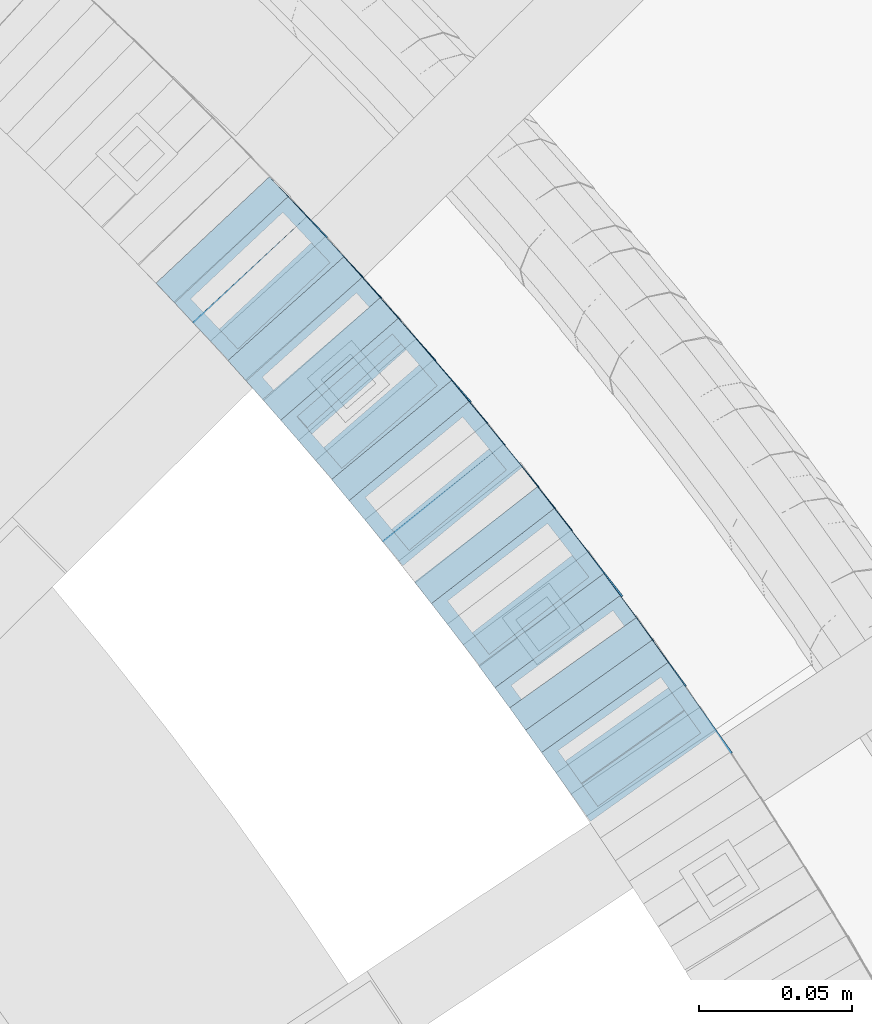
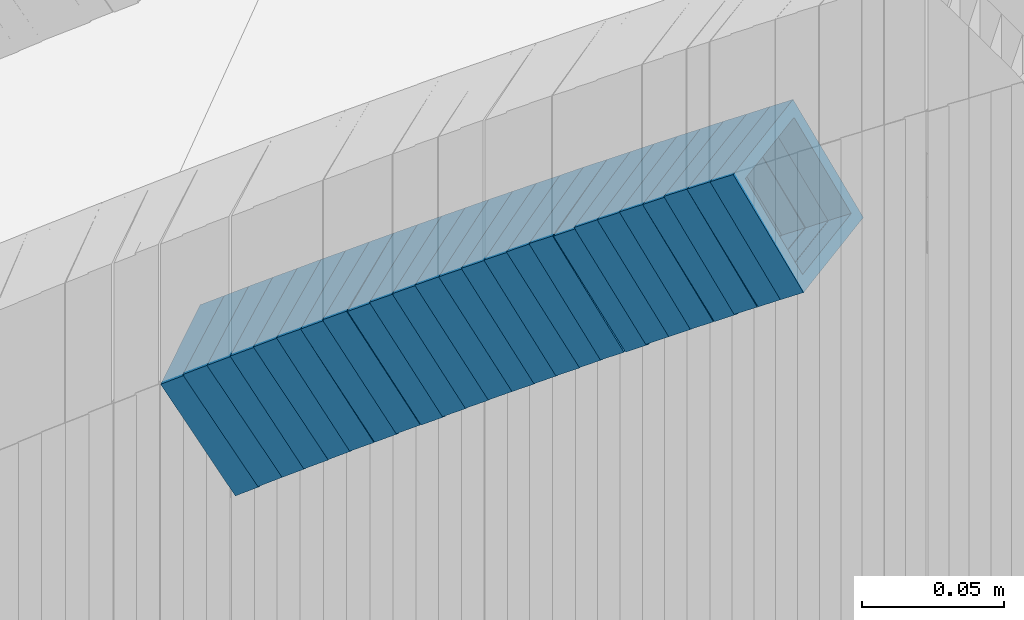
# One storey, part 804 of 975: 25 members.
"""IFC2X3 building model written with IfcOpenShell, lengths in millimetres."""

from ifc_helpers import new_model, si_unit, frame, origin_with_axes, place, context, subcontext, project, spatial, faceted_brep, material, type_object, element, save


model = new_model("IFC2X3")

# Units and contexts
model_context = context("Model", 3, precision=1e-05, world=origin_with_axes())
body_context = subcontext(model_context, "Body", "Model", "MODEL_VIEW")
ifc_project = project(units=[si_unit("LENGTHUNIT", "METRE", prefix="MILLI"), si_unit("AREAUNIT", "SQUARE_METRE"), si_unit("VOLUMEUNIT", "CUBIC_METRE"), si_unit("MASSUNIT", "GRAM", prefix="KILO"), si_unit("TIMEUNIT", "SECOND"), si_unit("PLANEANGLEUNIT", "RADIAN"), si_unit("SOLIDANGLEUNIT", "STERADIAN"), si_unit("THERMODYNAMICTEMPERATUREUNIT", "DEGREE_CELSIUS"), si_unit("LUMINOUSINTENSITYUNIT", "LUMEN")], contexts=[model_context])

# Site, building, storey
site_placement = place(None, origin_with_axes())
site = spatial("IfcSite", under=ifc_project, at=site_placement, CompositionType="ELEMENT")
building_placement = place(site_placement, origin_with_axes())
building = spatial("IfcBuilding", under=site, at=building_placement, Name="Undefined", CompositionType="ELEMENT")
storey_placement = place(building_placement, origin_with_axes())
storey = spatial("IfcBuildingStorey", under=building, at=storey_placement, Name="Undefined", CompositionType="ELEMENT", Elevation=0.0)

# Members
ifc_material = material()
member_type = type_object("IfcMemberType", Name="HSS2X2X.188_TUBES", PredefinedType="NOTDEFINED")
for number, where, z_axis, x_axis, name in (
    (1, (35883.1958449818, 4199.01896705083, 1917.16716838348), (0.814486661793431, 0.580182279771275, -2.11284714168869e-11), (0.48956492595936, -0.687273837943189, 0.536638476955618), "WALL"),
    (2, (35872.7958449818, 4213.61896705081, 1905.66716838342), (0.814486661793431, 0.580182279771275, -2.11284714168869e-11), (0.48956492595936, -0.687273837943189, 0.536638476955618), "WALL"),
):
    element("IfcMember", number, at=place(storey_placement, frame(where, z_axis=z_axis, x_axis=x_axis)), inside=storey, type_object=member_type, material=ifc_material, Name=name, ObjectType="HSS2X2X.188_TUBES", context=body_context, shape_type="Brep", body=[
        faceted_brep([(0.0, 20.6374999999753, -20.6375000000298), (0.0, -20.6375000000153, -20.6375000000153), (10.6216759506497, -20.637499999968, -20.6374999999534), (10.6216759506497, 20.6375000000262, -20.6374999999643), (0.0, -20.6374999999825, 20.6375000000335), (10.6216759506169, -20.6374999999935, 20.637500000008), (0.0, 20.6375000000116, 20.6375000000189), (10.6216759506242, 20.6375000000007, 20.6374999999971), (0.0, 25.3999999999724, -25.4000000000342), (0.0, 25.400000000016, 25.4000000000196), (10.6216759506169, 25.3999999999978, 25.3999999999869), (10.6216759506533, 25.4000000000269, -25.3999999999614), (0.0, -25.399999999976, 25.4000000000378), (10.6216759506242, -25.3999999999942, 25.4000000000051), (0.0, -25.400000000016, -25.4000000000196), (10.6216759506569, -25.3999999999614, -25.3999999999432)], [[[0, 1, 2, 3]], [[1, 4, 5, 2]], [[4, 6, 7, 5]], [[6, 0, 3, 7]], [[8, 9, 10, 11]], [[9, 12, 13, 10]], [[12, 14, 15, 13]], [[14, 8, 11, 15]], [[13, 15, 11, 10], [5, 7, 3, 2]], [[14, 12, 9, 8], [6, 4, 1, 0]]]),
    ])
member_1_placement = place(storey_placement, frame((35878.0938846065, 4206.18133450073, 1911.47557519376), z_axis=(0.814486661793431, 0.580182279771275, -2.11284714168869e-11), x_axis=(0.487088716912159, -0.683797621876746, 0.543291260902081)))
element("IfcMember", 3, at=member_1_placement, inside=storey, type_object=member_type, material=ifc_material, Name="WALL", ObjectType="HSS2X2X.188_TUBES", context=body_context, shape_type="Brep", body=[
    faceted_brep([(0.0, 20.6374999999753, -20.6375000000298), (0.0, -20.6375000000153, -20.6375000000153), (10.6831643251735, -20.6375000000498, -20.6375000000953), (10.6831643252044, 20.637499999988, -20.6375000000226), (0.0, -20.6374999999825, 20.6375000000335), (10.6831643251935, -20.6375000000135, 20.637499999968), (0.0, 20.6375000000116, 20.6375000000189), (10.6831643252244, 20.6375000000226, 20.6375000000407), (0.0, 25.3999999999724, -25.4000000000342), (0.0, 25.400000000016, 25.4000000000196), (10.6831643252317, 25.4000000000306, 25.4000000000597), (10.6831643252044, 25.3999999999905, -25.4000000000196), (0.0, -25.399999999976, 25.4000000000378), (10.6831643251917, -25.400000000016, 25.3999999999614), (0.0, -25.400000000016, -25.4000000000196), (10.6831643251644, -25.400000000056, -25.4000000001179)], [[[0, 1, 2, 3]], [[1, 4, 5, 2]], [[4, 6, 7, 5]], [[6, 0, 3, 7]], [[8, 9, 10, 11]], [[9, 12, 13, 10]], [[12, 14, 15, 13]], [[14, 8, 11, 15]], [[13, 15, 11, 10], [5, 7, 3, 2]], [[14, 12, 9, 8], [6, 4, 1, 0]]]),
])
member_2_placement = place(storey_placement, frame((35862.6148369527, 4227.80323975662, 1894.18259583676), z_axis=(0.805336884073592, 0.592817428177207, 3.1585841497872e-11), x_axis=(0.499866553847046, -0.679063997791858, 0.537592331835208)))
element("IfcMember", 4, at=member_2_placement, inside=storey, type_object=member_type, material=ifc_material, Name="WALL", ObjectType="HSS2X2X.188_TUBES", context=body_context, shape_type="Brep", body=[
    faceted_brep([(0.0, 20.6374999999753, -20.6375000000298), (0.0, -20.6375000000153, -20.6375000000153), (10.6004716875832, -20.6375000000153, -20.6375000000553), (10.6004716875814, 20.6374999999898, -20.6375000000444), (0.0, -20.6374999999825, 20.6375000000335), (10.6004716876068, -20.6375000000044, 20.6374999999862), (0.0, 20.6375000000116, 20.6375000000189), (10.6004716876032, 20.6374999999989, 20.6374999999971), (0.0, 25.3999999999724, -25.4000000000342), (0.0, 25.400000000016, 25.4000000000196), (10.600471687605, 25.4000000000015, 25.4000000000051), (10.6004716875814, 25.3999999999869, -25.4000000000487), (0.0, -25.399999999976, 25.4000000000378), (10.6004716876068, -25.4000000000015, 25.3999999999905), (0.0, -25.400000000016, -25.4000000000196), (10.6004716875814, -25.4000000000178, -25.4000000000669)], [[[0, 1, 2, 3]], [[1, 4, 5, 2]], [[4, 6, 7, 5]], [[6, 0, 3, 7]], [[8, 9, 10, 11]], [[9, 12, 13, 10]], [[12, 14, 15, 13]], [[14, 8, 11, 15]], [[13, 15, 11, 10], [5, 7, 3, 2]], [[14, 12, 9, 8], [6, 4, 1, 0]]]),
])
member_3_placement = place(storey_placement, frame((35868.0150426214, 4220.46711130099, 1899.99130712872), z_axis=(0.805336884073592, 0.592817428177207, 3.1585841497872e-11), x_axis=(0.497329311996885, -0.675617177995523, 0.544247171996393)))
element("IfcMember", 5, at=member_3_placement, inside=storey, type_object=member_type, material=ifc_material, Name="WALL", ObjectType="HSS2X2X.188_TUBES", context=body_context, shape_type="Brep", body=[
    faceted_brep([(0.0, 20.6374999999753, -20.6375000000298), (0.0, -20.6375000000153, -20.6375000000153), (10.6625512894789, -20.6374999999625, -20.6374999999389), (10.6625512893879, 20.6374999999789, -20.6375000000371), (0.0, -20.6374999999825, 20.6375000000335), (10.6625512894352, -20.6374999999989, 20.6375000000153), (0.0, 20.6375000000116, 20.6375000000189), (10.6625512893443, 20.6374999999443, 20.6374999999134), (0.0, 25.3999999999724, -25.4000000000342), (0.0, 25.400000000016, 25.4000000000196), (10.6625512893297, 25.3999999999342, 25.3999999998996), (10.6625512893916, 25.399999999976, -25.4000000000415), (0.0, -25.399999999976, 25.4000000000378), (10.6625512894389, -25.399999999996, 25.400000000016), (0.0, -25.400000000016, -25.4000000000196), (10.6625512894971, -25.3999999999523, -25.3999999999214)], [[[0, 1, 2, 3]], [[1, 4, 5, 2]], [[4, 6, 7, 5]], [[6, 0, 3, 7]], [[8, 9, 10, 11]], [[9, 12, 13, 10]], [[12, 14, 15, 13]], [[14, 8, 11, 15]], [[13, 15, 11, 10], [5, 7, 3, 2]], [[14, 12, 9, 8], [6, 4, 1, 0]]]),
])
member_4_placement = place(storey_placement, frame((35852.2110918987, 4241.91018183956, 1882.74949572793), z_axis=(0.799999999999881, 0.600000000000158, -1.28920873976312e-13), x_axis=(0.50434262096533, -0.672456827953377, 0.541701333962455)))
element("IfcMember", 6, at=member_4_placement, inside=storey, type_object=member_type, material=ifc_material, Name="WALL", ObjectType="HSS2X2X.188_TUBES", context=body_context, shape_type="Brep", body=[
    faceted_brep([(0.0, 20.6374999999753, -20.6375000000298), (0.0, -20.6375000000153, -20.6375000000153), (10.7093417165161, -20.637499999968, -20.6374999999534), (10.709341716436, 20.6374999999898, -20.6375000000116), (0.0, -20.6374999999825, 20.6375000000335), (10.7093417164688, -20.6374999999971, 20.6375000000153), (0.0, 20.6375000000116, 20.6375000000189), (10.7093417163924, 20.6374999999643, 20.6374999999571), (0.0, 25.3999999999724, -25.4000000000342), (0.0, 25.400000000016, 25.4000000000196), (10.7093417163815, 25.3999999999542, 25.3999999999469), (10.7093417164288, 25.3999999999869, -25.4000000000196), (0.0, -25.399999999976, 25.4000000000378), (10.7093417164724, -25.3999999999942, 25.4000000000196), (0.0, -25.400000000016, -25.4000000000196), (10.709341716527, -25.3999999999578, -25.3999999999432)], [[[0, 1, 2, 3]], [[1, 4, 5, 2]], [[4, 6, 7, 5]], [[6, 0, 3, 7]], [[8, 9, 10, 11]], [[9, 12, 13, 10]], [[12, 14, 15, 13]], [[14, 8, 11, 15]], [[13, 15, 11, 10], [5, 7, 3, 2]], [[14, 12, 9, 8], [6, 4, 1, 0]]]),
])
member_5_placement = place(storey_placement, frame((35857.541892579, 4234.75085307147, 1888.53875215851), z_axis=(0.801352360250022, 0.598192606709343, 2.46066747422447e-10), x_axis=(0.503076398950628, -0.673932534933828, 0.54104442994687)))
element("IfcMember", 7, at=member_5_placement, inside=storey, type_object=member_type, material=ifc_material, Name="WALL", ObjectType="HSS2X2X.188_TUBES", context=body_context, shape_type="Brep", body=[
    faceted_brep([(0.0, 20.6374999999753, -20.6375000000298), (0.0, -20.6375000000153, -20.6375000000153), (10.5422957651572, -20.6374999999771, -20.6374999999534), (10.5422957651481, 20.6375000000153, -20.6374999999789), (0.0, -20.6374999999825, 20.6375000000335), (10.5422957651535, -20.6374999999971, 20.6375000000298), (0.0, 20.6375000000116, 20.6375000000189), (10.5422957651444, 20.6374999999971, 20.6375000000044), (0.0, 25.3999999999724, -25.4000000000342), (0.0, 25.400000000016, 25.4000000000196), (10.5422957651426, 25.3999999999924, 25.3999999999905), (10.5422957651463, 25.4000000000178, -25.3999999999833), (0.0, -25.399999999976, 25.4000000000378), (10.5422957651499, -25.3999999999996, 25.4000000000269), (0.0, -25.400000000016, -25.4000000000196), (10.5422957651554, -25.3999999999742, -25.3999999999469)], [[[0, 1, 2, 3]], [[1, 4, 5, 2]], [[4, 6, 7, 5]], [[6, 0, 3, 7]], [[8, 9, 10, 11]], [[9, 12, 13, 10]], [[12, 14, 15, 13]], [[14, 8, 11, 15]], [[13, 15, 11, 10], [5, 7, 3, 2]], [[14, 12, 9, 8], [6, 4, 1, 0]]]),
])
member_6_placement = place(storey_placement, frame((35847.264966157, 4248.69520938853, 1877.009101935), z_axis=(0.786318338803167, 0.61782155195641, -5.59168711333768e-11), x_axis=(0.520305427078064, -0.662206907098976, 0.53922562508056)))
element("IfcMember", 8, at=member_6_placement, inside=storey, type_object=member_type, material=ifc_material, Name="WALL", ObjectType="HSS2X2X.188_TUBES", context=body_context, shape_type="Brep", body=[
    faceted_brep([(0.0, 20.6374999999753, -20.6375000000298), (0.0, -20.6375000000153, -20.6375000000153), (10.5744976239494, -20.6375000000207, -20.6375000000335), (10.5744976239657, 20.6375000000098, -20.637500000008), (0.0, -20.6374999999825, 20.6375000000335), (10.5744976239639, -20.6375000000244, 20.6374999999753), (0.0, 20.6375000000116, 20.6375000000189), (10.5744976239803, 20.6374999999989, 20.6374999999935), (0.0, 25.3999999999724, -25.4000000000342), (0.0, 25.400000000016, 25.4000000000196), (10.5744976239857, 25.4000000000051, 25.4000000000015), (10.5744976239675, 25.4000000000124, -25.4000000000051), (0.0, -25.399999999976, 25.4000000000378), (10.5744976239639, -25.4000000000287, 25.3999999999724), (0.0, -25.400000000016, -25.4000000000196), (10.5744976239494, -25.4000000000215, -25.4000000000378)], [[[0, 1, 2, 3]], [[1, 4, 5, 2]], [[4, 6, 7, 5]], [[6, 0, 3, 7]], [[8, 9, 10, 11]], [[9, 12, 13, 10]], [[12, 14, 15, 13]], [[14, 8, 11, 15]], [[13, 15, 11, 10], [5, 7, 3, 2]], [[14, 12, 9, 8], [6, 4, 1, 0]]]),
])
member_7_placement = place(storey_placement, frame((35841.5307762458, 4255.94269336412, 1871.25453112483), z_axis=(0.790549812362157, 0.61239774181014, 2.36018422583583e-10), x_axis=(0.517053414058718, -0.66746895307548, 0.535855357060603)))
element("IfcMember", 9, at=member_7_placement, inside=storey, type_object=member_type, material=ifc_material, Name="WALL", ObjectType="HSS2X2X.188_TUBES", context=body_context, shape_type="Brep", body=[
    faceted_brep([(0.0, 20.6374999999753, -20.6375000000298), (0.0, -20.6375000000153, -20.6375000000153), (10.6395488625676, -20.6374999999771, -20.6374999999716), (10.6395488625531, 20.6374999999916, -20.6375000000189), (0.0, -20.6374999999825, 20.6375000000335), (10.6395488625731, -20.6374999999844, 20.6375000000153), (0.0, 20.6375000000116, 20.6375000000189), (10.6395488625585, 20.6374999999825, 20.637499999968), (0.0, 25.3999999999724, -25.4000000000342), (0.0, 25.400000000016, 25.4000000000196), (10.6395488625567, 25.3999999999778, 25.3999999999614), (10.6395488625494, 25.3999999999887, -25.4000000000233), (0.0, -25.399999999976, 25.4000000000378), (10.6395488625749, -25.3999999999851, 25.400000000016), (0.0, -25.400000000016, -25.4000000000196), (10.6395488625658, -25.399999999976, -25.3999999999687)], [[[0, 1, 2, 3]], [[1, 4, 5, 2]], [[4, 6, 7, 5]], [[6, 0, 3, 7]], [[8, 9, 10, 11]], [[9, 12, 13, 10]], [[12, 14, 15, 13]], [[14, 8, 11, 15]], [[13, 15, 11, 10], [5, 7, 3, 2]], [[14, 12, 9, 8], [6, 4, 1, 0]]]),
])
for number, where, z_axis, x_axis, name in (
    (10, (35836.3694516945, 4262.66222779548, 1865.61833438348), (0.786318338803167, 0.61782155195641, -5.59168711333768e-11), (0.517648491999634, -0.658825352999709, 0.545883863999765), "WALL"),
    (11, (35830.8553430526, 4269.74798968334, 1859.7660161788), (0.78086880941289, 0.6246950475921, 3.66534777640482e-10), (0.527153683053312, -0.658942104066293, 0.536567142054016), "WALL"),
):
    element("IfcMember", number, at=place(storey_placement, frame(where, z_axis=z_axis, x_axis=x_axis)), inside=storey, type_object=member_type, material=ifc_material, Name=name, ObjectType="HSS2X2X.188_TUBES", context=body_context, shape_type="Brep", body=[
        faceted_brep([(0.0, 20.6374999999753, -20.6375000000298), (0.0, -20.6375000000153, -20.6375000000153), (10.6216759506497, -20.637499999968, -20.6374999999534), (10.6216759506497, 20.6375000000262, -20.6374999999643), (0.0, -20.6374999999825, 20.6375000000335), (10.6216759506169, -20.6374999999935, 20.637500000008), (0.0, 20.6375000000116, 20.6375000000189), (10.6216759506242, 20.6375000000007, 20.6374999999971), (0.0, 25.3999999999724, -25.4000000000342), (0.0, 25.400000000016, 25.4000000000196), (10.6216759506169, 25.3999999999978, 25.3999999999869), (10.6216759506533, 25.4000000000269, -25.3999999999614), (0.0, -25.399999999976, 25.4000000000378), (10.6216759506242, -25.3999999999942, 25.4000000000051), (0.0, -25.400000000016, -25.4000000000196), (10.6216759506569, -25.3999999999614, -25.3999999999432)], [[[0, 1, 2, 3]], [[1, 4, 5, 2]], [[4, 6, 7, 5]], [[6, 0, 3, 7]], [[8, 9, 10, 11]], [[9, 12, 13, 10]], [[12, 14, 15, 13]], [[14, 8, 11, 15]], [[13, 15, 11, 10], [5, 7, 3, 2]], [[14, 12, 9, 8], [6, 4, 1, 0]]]),
    ])
member_8_placement = place(storey_placement, frame((35825.4953637898, 4276.50328690906, 1854.12011987273), z_axis=(0.776458094254318, 0.630168888367993, -8.04775481810794e-11), x_axis=(0.530430523998559, -0.653566180998582, 0.539902496998803)))
element("IfcMember", 12, at=member_8_placement, inside=storey, type_object=member_type, material=ifc_material, Name="WALL", ObjectType="HSS2X2X.188_TUBES", context=body_context, shape_type="Brep", body=[
    faceted_brep([(0.0, 20.6374999999753, -20.6375000000298), (0.0, -20.6375000000153, -20.6375000000153), (10.5550935571373, -20.6374999999935, -20.6374999999753), (10.5550935571373, 20.6375000000025, -20.6374999999862), (0.0, -20.6374999999825, 20.6375000000335), (10.5550935571027, -20.6374999999989, 20.6374999999862), (0.0, 20.6375000000116, 20.6375000000189), (10.5550935571027, 20.6374999999953, 20.6374999999716), (0.0, 25.3999999999724, -25.4000000000342), (0.0, 25.400000000016, 25.4000000000196), (10.5550935570991, 25.3999999999924, 25.3999999999651), (10.5550935571373, 25.3999999999996, -25.3999999999905), (0.0, -25.399999999976, 25.4000000000378), (10.5550935571009, -25.3999999999996, 25.3999999999833), (0.0, -25.400000000016, -25.4000000000196), (10.5550935571428, -25.3999999999905, -25.3999999999724)], [[[0, 1, 2, 3]], [[1, 4, 5, 2]], [[4, 6, 7, 5]], [[6, 0, 3, 7]], [[8, 9, 10, 11]], [[9, 12, 13, 10]], [[12, 14, 15, 13]], [[14, 8, 11, 15]], [[13, 15, 11, 10], [5, 7, 3, 2]], [[14, 12, 9, 8], [6, 4, 1, 0]]]),
])
member_9_placement = place(storey_placement, frame((35819.9830847359, 4283.3613514475, 1848.37602441666), z_axis=(0.77096175158008, 0.636881447053198, -1.96447672351497e-10), x_axis=(0.537186322222744, -0.650278179269348, 0.537186322222508)))
element("IfcMember", 13, at=member_9_placement, inside=storey, type_object=member_type, material=ifc_material, Name="WALL", ObjectType="HSS2X2X.188_TUBES", context=body_context, shape_type="Brep", body=[
    faceted_brep([(0.0, 20.6374999999753, -20.6375000000298), (0.0, -20.6375000000153, -20.6375000000153), (10.6061303028146, -20.6374999999571, -20.6374999999643), (10.6061303027491, 20.6374999999971, -20.6375000000007), (0.0, -20.6374999999825, 20.6375000000335), (10.6061303027855, -20.6374999999825, 20.6375000000116), (0.0, 20.6375000000116, 20.6375000000189), (10.6061303027236, 20.637499999968, 20.6374999999716), (0.0, 25.3999999999724, -25.4000000000342), (0.0, 25.400000000016, 25.4000000000196), (10.6061303027163, 25.3999999999651, 25.3999999999651), (10.6061303027454, 25.3999999999942, -25.4000000000051), (0.0, -25.399999999976, 25.4000000000378), (10.6061303027891, -25.3999999999796, 25.4000000000124), (0.0, -25.400000000016, -25.4000000000196), (10.6061303028182, -25.3999999999505, -25.3999999999542)], [[[0, 1, 2, 3]], [[1, 4, 5, 2]], [[4, 6, 7, 5]], [[6, 0, 3, 7]], [[8, 9, 10, 11]], [[9, 12, 13, 10]], [[12, 14, 15, 13]], [[14, 8, 11, 15]], [[13, 15, 11, 10], [5, 7, 3, 2]], [[14, 12, 9, 8], [6, 4, 1, 0]]]),
])
member_10_placement = place(storey_placement, frame((35814.3907246248, 4290.13105052934, 1842.68460611629), z_axis=(0.77096175158008, 0.636881447053198, -1.96447672351497e-10), x_axis=(0.53446373709098, -0.646982418110177, 0.543840293092606)))
element("IfcMember", 14, at=member_10_placement, inside=storey, type_object=member_type, material=ifc_material, Name="WALL", ObjectType="HSS2X2X.188_TUBES", context=body_context, shape_type="Brep", body=[
    faceted_brep([(0.0, 20.6374999999753, -20.6375000000298), (0.0, -20.6375000000153, -20.6375000000153), (10.6625512894789, -20.6374999999625, -20.6374999999389), (10.6625512893879, 20.6374999999789, -20.6375000000371), (0.0, -20.6374999999825, 20.6375000000335), (10.6625512894352, -20.6374999999989, 20.6375000000153), (0.0, 20.6375000000116, 20.6375000000189), (10.6625512893443, 20.6374999999443, 20.6374999999134), (0.0, 25.3999999999724, -25.4000000000342), (0.0, 25.400000000016, 25.4000000000196), (10.6625512893297, 25.3999999999342, 25.3999999998996), (10.6625512893916, 25.399999999976, -25.4000000000415), (0.0, -25.399999999976, 25.4000000000378), (10.6625512894389, -25.399999999996, 25.400000000016), (0.0, -25.400000000016, -25.4000000000196), (10.6625512894971, -25.3999999999523, -25.3999999999214)], [[[0, 1, 2, 3]], [[1, 4, 5, 2]], [[4, 6, 7, 5]], [[6, 0, 3, 7]], [[8, 9, 10, 11]], [[9, 12, 13, 10]], [[12, 14, 15, 13]], [[14, 8, 11, 15]], [[13, 15, 11, 10], [5, 7, 3, 2]], [[14, 12, 9, 8], [6, 4, 1, 0]]]),
])
member_11_placement = place(storey_placement, frame((35808.8288035727, 4296.91964989508, 1836.92961252592), z_axis=(0.766370514309658, 0.64239881288554, 1.84137206815648e-10), x_axis=(0.540484706978791, -0.644788773974845, 0.540484706978899)))
element("IfcMember", 15, at=member_11_placement, inside=storey, type_object=member_type, material=ifc_material, Name="WALL", ObjectType="HSS2X2X.188_TUBES", context=body_context, shape_type="Brep", body=[
    faceted_brep([(0.0, 20.6374999999753, -20.6375000000298), (0.0, -20.6375000000153, -20.6375000000153), (10.5531985672587, -20.6374999999916, -20.6375000000007), (10.5531985672878, 20.6375000000062, -20.6374999999789), (0.0, -20.6374999999825, 20.6375000000335), (10.5531985672114, -20.6375000000353, 20.6374999999171), (0.0, 20.6375000000116, 20.6375000000189), (10.5531985672333, 20.6374999999607, 20.6374999999316), (0.0, 25.3999999999724, -25.4000000000342), (0.0, 25.400000000016, 25.4000000000196), (10.5531985672314, 25.399999999956, 25.3999999999251), (10.5531985672933, 25.4000000000106, -25.3999999999724), (0.0, -25.399999999976, 25.4000000000378), (10.5531985672023, -25.4000000000397, 25.3999999999069), (0.0, -25.400000000016, -25.4000000000196), (10.5531985672642, -25.3999999999851, -25.3999999999869)], [[[0, 1, 2, 3]], [[1, 4, 5, 2]], [[4, 6, 7, 5]], [[6, 0, 3, 7]], [[8, 9, 10, 11]], [[9, 12, 13, 10]], [[12, 14, 15, 13]], [[14, 8, 11, 15]], [[13, 15, 11, 10], [5, 7, 3, 2]], [[14, 12, 9, 8], [6, 4, 1, 0]]]),
])
member_12_placement = place(storey_placement, frame((35803.2136178863, 4303.68292819552, 1831.18453277567), z_axis=(0.760833952036961, 0.648946605991447, 1.94459062186069e-11), x_axis=(0.547145463784403, -0.641480888746839, 0.537711921787789)))
element("IfcMember", 16, at=member_12_placement, inside=storey, type_object=member_type, material=ifc_material, Name="WALL", ObjectType="HSS2X2X.188_TUBES", context=body_context, shape_type="Brep", body=[
    faceted_brep([(0.0, 20.6374999999753, -20.6375000000298), (0.0, -20.6375000000153, -20.6375000000153), (10.6004716875832, -20.6375000000153, -20.6375000000553), (10.6004716875814, 20.6374999999898, -20.6375000000444), (0.0, -20.6374999999825, 20.6375000000335), (10.6004716876068, -20.6375000000044, 20.6374999999862), (0.0, 20.6375000000116, 20.6375000000189), (10.6004716876032, 20.6374999999989, 20.6374999999971), (0.0, 25.3999999999724, -25.4000000000342), (0.0, 25.400000000016, 25.4000000000196), (10.600471687605, 25.4000000000015, 25.4000000000051), (10.6004716875814, 25.3999999999869, -25.4000000000487), (0.0, -25.399999999976, 25.4000000000378), (10.6004716876068, -25.4000000000015, 25.3999999999905), (0.0, -25.400000000016, -25.4000000000196), (10.6004716875814, -25.4000000000178, -25.4000000000669)], [[[0, 1, 2, 3]], [[1, 4, 5, 2]], [[4, 6, 7, 5]], [[6, 0, 3, 7]], [[8, 9, 10, 11]], [[9, 12, 13, 10]], [[12, 14, 15, 13]], [[14, 8, 11, 15]], [[13, 15, 11, 10], [5, 7, 3, 2]], [[14, 12, 9, 8], [6, 4, 1, 0]]]),
])
member_13_placement = place(storey_placement, frame((35797.7465500807, 4310.21285038669, 1825.49152150851), z_axis=(0.750491265210853, 0.660880368026025, 7.65005552239016e-11), x_axis=(0.55702532101345, -0.63255417801512, 0.538143107012883)))
element("IfcMember", 17, at=member_13_placement, inside=storey, type_object=member_type, material=ifc_material, Name="WALL", ObjectType="HSS2X2X.188_TUBES", context=body_context, shape_type="Brep", body=[
    faceted_brep([(0.0, 20.6374999999753, -20.6375000000298), (0.0, -20.6375000000153, -20.6375000000153), (10.5948100501191, -20.6375000000335, -20.6375000000844), (10.5948100501555, 20.6374999999971, -20.6375000000116), (0.0, -20.6374999999825, 20.6375000000335), (10.5948100501446, -20.6375000000098, 20.6374999999571), (0.0, 20.6375000000116, 20.6375000000189), (10.5948100501828, 20.6375000000189, 20.6375000000298), (0.0, 25.3999999999724, -25.4000000000342), (0.0, 25.400000000016, 25.4000000000196), (10.5948100501919, 25.4000000000251, 25.4000000000451), (10.5948100501591, 25.3999999999978, -25.4000000000051), (0.0, -25.399999999976, 25.4000000000378), (10.5948100501482, -25.4000000000106, 25.3999999999578), (0.0, -25.400000000016, -25.4000000000196), (10.5948100501118, -25.4000000000378, -25.400000000096)], [[[0, 1, 2, 3]], [[1, 4, 5, 2]], [[4, 6, 7, 5]], [[6, 0, 3, 7]], [[8, 9, 10, 11]], [[9, 12, 13, 10]], [[12, 14, 15, 13]], [[14, 8, 11, 15]], [[13, 15, 11, 10], [5, 7, 3, 2]], [[14, 12, 9, 8], [6, 4, 1, 0]]]),
])
member_14_placement = place(storey_placement, frame((35791.7055535977, 4317.02120093396, 1819.74756298552), z_axis=(0.755322467381449, 0.655353317126571, 9.94618858385367e-11), x_axis=(0.550920883378724, -0.634959662436692, 0.541583241372448)))
element("IfcMember", 18, at=member_14_placement, inside=storey, type_object=member_type, material=ifc_material, Name="WALL", ObjectType="HSS2X2X.188_TUBES", context=body_context, shape_type="Brep", body=[
    faceted_brep([(0.0, 20.6374999999753, -20.6375000000298), (0.0, -20.6375000000153, -20.6375000000153), (10.7093417165161, -20.637499999968, -20.6374999999534), (10.709341716436, 20.6374999999898, -20.6375000000116), (0.0, -20.6374999999825, 20.6375000000335), (10.7093417164688, -20.6374999999971, 20.6375000000153), (0.0, 20.6375000000116, 20.6375000000189), (10.7093417163924, 20.6374999999643, 20.6374999999571), (0.0, 25.3999999999724, -25.4000000000342), (0.0, 25.400000000016, 25.4000000000196), (10.7093417163815, 25.3999999999542, 25.3999999999469), (10.7093417164288, 25.3999999999869, -25.4000000000196), (0.0, -25.399999999976, 25.4000000000378), (10.7093417164724, -25.3999999999942, 25.4000000000196), (0.0, -25.400000000016, -25.4000000000196), (10.709341716527, -25.3999999999578, -25.3999999999432)], [[[0, 1, 2, 3]], [[1, 4, 5, 2]], [[4, 6, 7, 5]], [[6, 0, 3, 7]], [[8, 9, 10, 11]], [[9, 12, 13, 10]], [[12, 14, 15, 13]], [[14, 8, 11, 15]], [[13, 15, 11, 10], [5, 7, 3, 2]], [[14, 12, 9, 8], [6, 4, 1, 0]]]),
])
member_15_placement = place(storey_placement, frame((35786.2032093719, 4323.47778755363, 1814.04393655048), z_axis=(0.745536674369062, 0.666464603089106, 1.15596776595339e-10), x_axis=(0.560356707259313, -0.626839706290044, 0.541361564250466)))
element("IfcMember", 19, at=member_15_placement, inside=storey, type_object=member_type, material=ifc_material, Name="WALL", ObjectType="HSS2X2X.188_TUBES", context=body_context, shape_type="Brep", body=[
    faceted_brep([(0.0, 20.6374999999753, -20.6375000000298), (0.0, -20.6375000000153, -20.6375000000153), (10.5290075505945, -20.637499999968, -20.6375000000116), (10.5290075505436, 20.6374999999898, -20.637499999998), (0.0, -20.6374999999825, 20.6375000000335), (10.5290075505145, -20.6375000000189, 20.637500000008), (0.0, 20.6375000000116, 20.6375000000189), (10.5290075504672, 20.6374999999462, 20.6375000000198), (0.0, 25.3999999999724, -25.4000000000342), (0.0, 25.400000000016, 25.4000000000196), (10.5290075504563, 25.399999999936, 25.4000000000224), (10.5290075505472, 25.3999999999869, -25.3999999999987), (0.0, -25.399999999976, 25.4000000000378), (10.5290075505072, -25.4000000000196, 25.4000000000106), (0.0, -25.400000000016, -25.4000000000196), (10.5290075506091, -25.3999999999651, -25.4000000000151)], [[[0, 1, 2, 3]], [[1, 4, 5, 2]], [[4, 6, 7, 5]], [[6, 0, 3, 7]], [[8, 9, 10, 11]], [[9, 12, 13, 10]], [[12, 14, 15, 13]], [[14, 8, 11, 15]], [[13, 15, 11, 10], [5, 7, 3, 2]], [[14, 12, 9, 8], [6, 4, 1, 0]]]),
])
member_16_placement = place(storey_placement, frame((35780.1245927158, 4330.28368289049, 1808.2457712126), z_axis=(0.744950446796801, 0.667119803196732, -1.78793698069058e-10), x_axis=(0.563485862173899, -0.629225879194339, 0.535311569165331)))
element("IfcMember", 20, at=member_16_placement, inside=storey, type_object=member_type, material=ifc_material, Name="WALL", ObjectType="HSS2X2X.188_TUBES", context=body_context, shape_type="Brep", body=[
    faceted_brep([(0.0, 20.6374999999753, -20.6375000000298), (0.0, -20.6375000000153, -20.6375000000153), (10.648004507897, -20.6374999999862, -20.637499999968), (10.6480045078188, 20.6374999999771, -20.6375000000808), (0.0, -20.6374999999825, 20.6375000000335), (10.6480045079406, -20.6374999999698, 20.6375000001062), (0.0, 20.6375000000116, 20.6375000000189), (10.6480045078679, 20.6374999999935, 20.6375000000007), (0.0, 25.3999999999724, -25.4000000000342), (0.0, 25.400000000016, 25.4000000000196), (10.6480045078661, 25.3999999999905, 25.4000000000015), (10.648004507806, 25.3999999999705, -25.4000000000997), (0.0, -25.399999999976, 25.4000000000378), (10.6480045079552, -25.3999999999633, 25.4000000001288), (0.0, -25.400000000016, -25.4000000000196), (10.6480045078988, -25.3999999999814, -25.3999999999651)], [[[0, 1, 2, 3]], [[1, 4, 5, 2]], [[4, 6, 7, 5]], [[6, 0, 3, 7]], [[8, 9, 10, 11]], [[9, 12, 13, 10]], [[12, 14, 15, 13]], [[14, 8, 11, 15]], [[13, 15, 11, 10], [5, 7, 3, 2]], [[14, 12, 9, 8], [6, 4, 1, 0]]]),
])
for number, where, z_axis, x_axis, name in (
    (21, (35768.4560808745, 4343.32695820076, 1796.75033671614), (0.734376708367177, 0.678742108762813, 2.68535359282396e-10), (0.573180696785228, -0.620162721767513, 0.535595077799182), "WALL"),
    (22, (35774.4952170961, 4336.62611944692, 1802.60596860511), (0.739940073531935, 0.672672793846723, 3.0641967896372e-10), (0.563933684968898, -0.620327053966066, 0.545135895970153), "WALL"),
):
    element("IfcMember", number, at=place(storey_placement, frame(where, z_axis=z_axis, x_axis=x_axis)), inside=storey, type_object=member_type, material=ifc_material, Name=name, ObjectType="HSS2X2X.188_TUBES", context=body_context, shape_type="Brep", body=[
        faceted_brep([(0.0, 20.6374999999753, -20.6375000000298), (0.0, -20.6375000000153, -20.6375000000153), (10.6395488625676, -20.6374999999771, -20.6374999999716), (10.6395488625531, 20.6374999999916, -20.6375000000189), (0.0, -20.6374999999825, 20.6375000000335), (10.6395488625731, -20.6374999999844, 20.6375000000153), (0.0, 20.6375000000116, 20.6375000000189), (10.6395488625585, 20.6374999999825, 20.637499999968), (0.0, 25.3999999999724, -25.4000000000342), (0.0, 25.400000000016, 25.4000000000196), (10.6395488625567, 25.3999999999778, 25.3999999999614), (10.6395488625494, 25.3999999999887, -25.4000000000233), (0.0, -25.399999999976, 25.4000000000378), (10.6395488625749, -25.3999999999851, 25.400000000016), (0.0, -25.400000000016, -25.4000000000196), (10.6395488625658, -25.399999999976, -25.3999999999687)], [[[0, 1, 2, 3]], [[1, 4, 5, 2]], [[4, 6, 7, 5]], [[6, 0, 3, 7]], [[8, 9, 10, 11]], [[9, 12, 13, 10]], [[12, 14, 15, 13]], [[14, 8, 11, 15]], [[13, 15, 11, 10], [5, 7, 3, 2]], [[14, 12, 9, 8], [6, 4, 1, 0]]]),
    ])
member_17_placement = place(storey_placement, frame((35756.633718598, 4356.07485323639, 1785.40994937515), z_axis=(0.729187266859689, 0.684314204039121, 4.05166247219314e-11), x_axis=(0.573585986715012, -0.611198182696342, 0.545376839729059)))
element("IfcMember", 23, at=member_17_placement, inside=storey, type_object=member_type, material=ifc_material, Name="WALL", ObjectType="HSS2X2X.188_TUBES", context=body_context, shape_type="Brep", body=[
    faceted_brep([(0.0, 20.6374999999753, -20.6375000000298), (0.0, -20.6375000000153, -20.6375000000153), (10.6348483769107, -20.637499999988, -20.6374999999825), (10.6348483768415, 20.6374999999734, -20.6375000001026), (0.0, -20.6374999999825, 20.6375000000335), (10.6348483769852, -20.6374999999589, 20.6375000001462), (0.0, 20.6375000000116, 20.6375000000189), (10.6348483769161, 20.6375000000044, 20.6375000000226), (0.0, 25.3999999999724, -25.4000000000342), (0.0, 25.400000000016, 25.4000000000196), (10.6348483769179, 25.4000000000015, 25.4000000000233), (10.6348483768288, 25.3999999999669, -25.4000000001324), (0.0, -25.399999999976, 25.4000000000378), (10.6348483769998, -25.3999999999505, 25.4000000001688), (0.0, -25.400000000016, -25.4000000000196), (10.6348483769107, -25.3999999999887, -25.3999999999833)], [[[0, 1, 2, 3]], [[1, 4, 5, 2]], [[4, 6, 7, 5]], [[6, 0, 3, 7]], [[8, 9, 10, 11]], [[9, 12, 13, 10]], [[12, 14, 15, 13]], [[14, 8, 11, 15]], [[13, 15, 11, 10], [5, 7, 3, 2]], [[14, 12, 9, 8], [6, 4, 1, 0]]]),
])
for number, where, z_axis, x_axis, name in (
    (24, (35762.6180058957, 4349.69815365694, 1791.10087834955), (0.729187266859689, 0.684314204039121, 4.05166247219314e-11), (0.576524524206758, -0.614329411220455, 0.538719637193318), "WALL"),
    (25, (35750.7557133973, 4362.45369486297, 1779.60322447308), (0.718240222846442, 0.695795215767897, 3.82917733077193e-11), (0.586132836859933, -0.605040347855685, 0.538864059871503), "WALL"),
):
    element("IfcMember", number, at=place(storey_placement, frame(where, z_axis=z_axis, x_axis=x_axis)), inside=storey, type_object=member_type, material=ifc_material, Name=name, ObjectType="HSS2X2X.188_TUBES", context=body_context, shape_type="Brep", body=[
        faceted_brep([(0.0, 20.6374999999753, -20.6375000000298), (0.0, -20.6375000000153, -20.6375000000153), (10.5806427026419, -20.6374999999607, -20.6374999999316), (10.5806427026473, 20.6375000000444, -20.6374999999207), (0.0, -20.6374999999825, 20.6375000000335), (10.5806427025509, -20.6375000000207, 20.6374999999643), (0.0, 20.6375000000116, 20.6375000000189), (10.5806427025545, 20.6374999999862, 20.6374999999716), (0.0, 25.3999999999724, -25.4000000000342), (0.0, 25.400000000016, 25.4000000000196), (10.5806427025436, 25.3999999999796, 25.3999999999614), (10.5806427026582, 25.4000000000542, -25.3999999999105), (0.0, -25.399999999976, 25.4000000000378), (10.5806427025418, -25.4000000000287, 25.3999999999542), (0.0, -25.400000000016, -25.4000000000196), (10.5806427026528, -25.3999999999542, -25.3999999999178)], [[[0, 1, 2, 3]], [[1, 4, 5, 2]], [[4, 6, 7, 5]], [[6, 0, 3, 7]], [[8, 9, 10, 11]], [[9, 12, 13, 10]], [[12, 14, 15, 13]], [[14, 8, 11, 15]], [[13, 15, 11, 10], [5, 7, 3, 2]], [[14, 12, 9, 8], [6, 4, 1, 0]]]),
    ])

save(model, "model.ifc")
